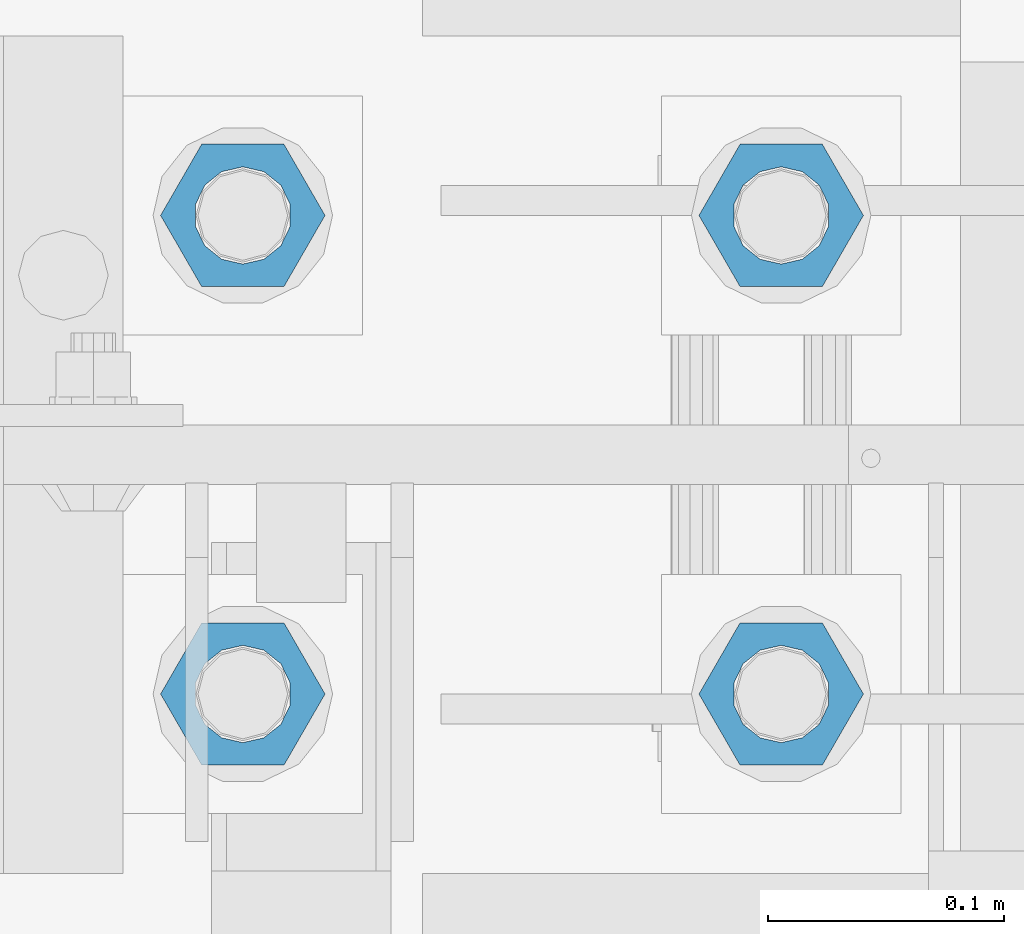
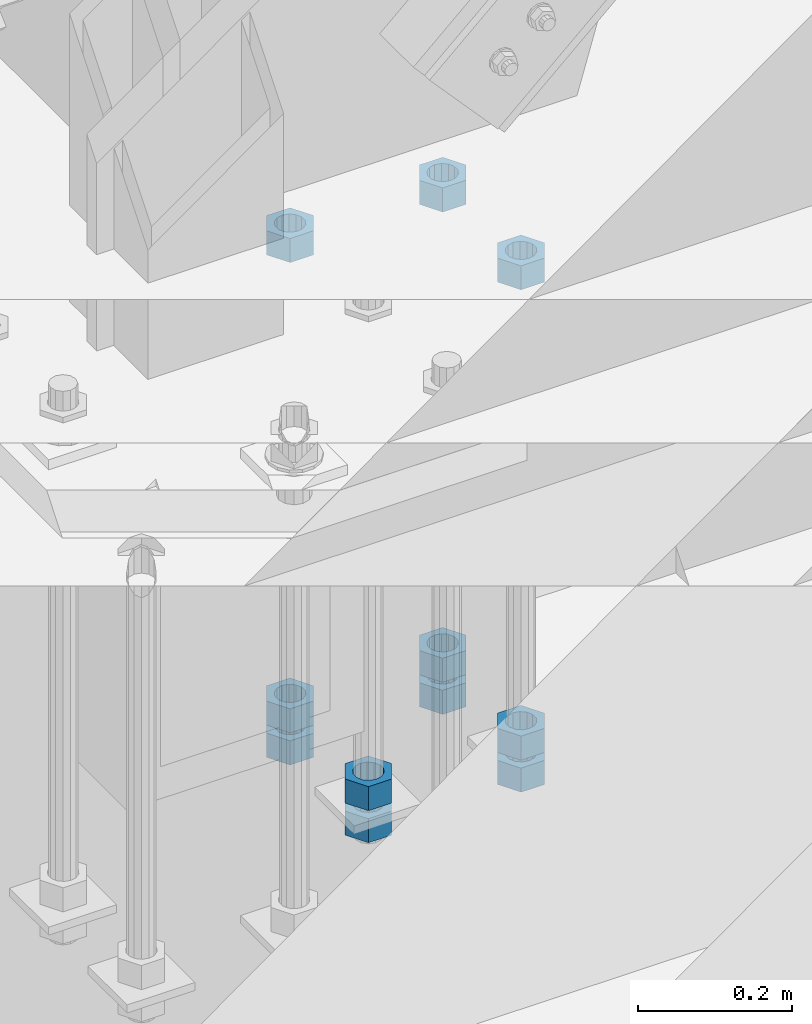
# One storey, part 980 of 1763: 11 columns, 1 element without a shape of its own.
"""IFC2X3 building model written with IfcOpenShell, lengths in millimetres."""

from ifc_helpers import new_model, si_unit, frame, origin_with_axes, place, context, subcontext, project, spatial, faceted_brep, material, type_object, element, aggregate, save


model = new_model("IFC2X3")

# Units and contexts
model_context = context("Model", 3, precision=1e-05, world=origin_with_axes())
body_context = subcontext(model_context, "Body", "Model", "MODEL_VIEW")
ifc_project = project(units=[si_unit("LENGTHUNIT", "METRE", prefix="MILLI"), si_unit("AREAUNIT", "SQUARE_METRE"), si_unit("VOLUMEUNIT", "CUBIC_METRE"), si_unit("MASSUNIT", "GRAM", prefix="KILO"), si_unit("TIMEUNIT", "SECOND"), si_unit("PLANEANGLEUNIT", "RADIAN"), si_unit("SOLIDANGLEUNIT", "STERADIAN"), si_unit("THERMODYNAMICTEMPERATUREUNIT", "DEGREE_CELSIUS"), si_unit("LUMINOUSINTENSITYUNIT", "LUMEN")], contexts=[model_context])

# Site, building, storey
site_placement = place(None, origin_with_axes())
site = spatial("IfcSite", under=ifc_project, at=site_placement, CompositionType="ELEMENT")
building_placement = place(site_placement, origin_with_axes())
building = spatial("IfcBuilding", under=site, at=building_placement, Name="Undefined", CompositionType="ELEMENT")
storey_placement = place(building_placement, origin_with_axes())
storey = spatial("IfcBuildingStorey", under=building, at=storey_placement, Name="Undefined", CompositionType="ELEMENT", Elevation=0.0)

# Assembly, columns
assembly_placement = place(storey_placement, origin_with_axes())
assembly = element("IfcElementAssembly", 1, at=assembly_placement, inside=storey, Name="TEMPLATE", AssemblyPlace="NOTDEFINED", PredefinedType="RIGID_FRAME")
ifc_material = material(Name="STEEL/A563")
column_type = type_object("IfcColumnType", Name="1-1/2_HEAVY_HEX_NUT", PredefinedType="NOTDEFINED")
column_1_placement = place(assembly_placement, frame((-87146.8372736983, -13817.6, 4445.00000000001), z_axis=(0.0, 1.0, 0.0), x_axis=(0.0, 0.0, -1.0)))
column_1 = element("IfcColumn", 2, at=column_1_placement, type_object=column_type, material=ifc_material, Name="NUT", ObjectType="1-1/2_HEAVY_HEX_NUT", context=body_context, shape_type="Brep", body=[
    faceted_brep([(0.0, -34.9199981689453, 0.0), (0.0, -17.4599990844727, -30.25), (38.1000000000004, -17.4599990844727, -30.25), (38.1000000000004, -34.9199981689453, 0.0), (0.0, 17.4599990844727, -30.25), (38.1000000000004, 17.4599990844727, -30.25), (0.0, 34.9199981689453, 0.0), (38.1000000000004, 34.9199981689453, 0.0), (0.0, 17.4599990844727, 30.25), (38.1000000000004, 17.4599990844727, 30.25), (0.0, -17.4599990844727, 30.25), (38.1000000000004, -17.4599990844727, 30.25), (0.0, 0.0, 20.6399993896484), (0.0, 8.95536011056538, 18.5959968835978), (38.1000000000004, 8.95536011056538, 18.5959968835978), (38.1000000000004, 0.0, 20.6399993896484), (0.0, 16.1370013209453, 12.8688291298167), (38.1000000000004, 16.1370013209453, 12.8688291298167), (0.0, 20.1225115123816, 4.59283194104137), (38.1000000000004, 20.1225115123816, 4.59283194104137), (0.0, 20.1225115123816, -4.59283194104319), (38.1000000000004, 20.1225115123816, -4.59283194104319), (0.0, 16.1370013209453, -12.8688291298167), (38.1000000000004, 16.1370013209453, -12.8688291298167), (0.0, 8.95536011056538, -18.5959968835978), (38.1000000000004, 8.95536011056538, -18.5959968835978), (0.0, 0.0, -20.6399993896484), (38.1000000000004, 0.0, -20.6399993896484), (0.0, -8.95536011056538, -18.5959968835978), (38.1000000000004, -8.95536011056538, -18.5959968835978), (0.0, -16.1370013209453, -12.8688291298167), (38.1000000000004, -16.1370013209453, -12.8688291298167), (0.0, -20.1225115123816, -4.59283194104137), (38.1000000000004, -20.1225115123816, -4.59283194104137), (0.0, -20.1225115123816, 4.59283194104319), (38.1000000000004, -20.1225115123816, 4.59283194104319), (0.0, -16.1370013209453, 12.8688291298167), (38.1000000000004, -16.1370013209453, 12.8688291298167), (0.0, -8.95536011056538, 18.5959968835978), (38.1000000000004, -8.95536011056538, 18.5959968835978)], [[[0, 1, 2, 3]], [[1, 4, 5, 2]], [[4, 6, 7, 5]], [[6, 8, 9, 7]], [[8, 10, 11, 9]], [[10, 0, 3, 11]], [[12, 13, 14, 15]], [[13, 16, 17, 14]], [[16, 18, 19, 17]], [[18, 20, 21, 19]], [[20, 22, 23, 21]], [[22, 24, 25, 23]], [[24, 26, 27, 25]], [[26, 28, 29, 27]], [[28, 30, 31, 29]], [[30, 32, 33, 31]], [[32, 34, 35, 33]], [[34, 36, 37, 35]], [[36, 38, 39, 37]], [[38, 12, 15, 39]], [[5, 7, 9, 11, 3, 2], [17, 19, 21, 23, 25, 27, 29, 31, 33, 35, 37, 39, 15, 14]], [[10, 8, 6, 4, 1, 0], [38, 36, 34, 32, 30, 28, 26, 24, 22, 20, 18, 16, 13, 12]]]),
])
column_2_placement = place(assembly_placement, frame((-87146.8372736983, -13817.6, 4394.20000000001), z_axis=(0.0, 1.0, 0.0), x_axis=(0.0, 0.0, -1.0)))
column_2 = element("IfcColumn", 3, at=column_2_placement, type_object=column_type, material=ifc_material, Name="NUT", ObjectType="1-1/2_HEAVY_HEX_NUT", context=body_context, shape_type="Brep", body=[
    faceted_brep([(0.0, -34.9199981689453, 0.0), (0.0, -17.4599990844727, -30.25), (38.1000000000004, -17.4599990844727, -30.25), (38.1000000000004, -34.9199981689453, 0.0), (0.0, 17.4599990844727, -30.25), (38.1000000000004, 17.4599990844727, -30.25), (0.0, 34.9199981689453, 0.0), (38.1000000000004, 34.9199981689453, 0.0), (0.0, 17.4599990844727, 30.25), (38.1000000000004, 17.4599990844727, 30.25), (0.0, -17.4599990844727, 30.25), (38.1000000000004, -17.4599990844727, 30.25), (0.0, 0.0, 20.6399993896484), (0.0, 8.95536011056538, 18.5959968835978), (38.1000000000004, 8.95536011056538, 18.5959968835978), (38.1000000000004, 0.0, 20.6399993896484), (0.0, 16.1370013209453, 12.8688291298167), (38.1000000000004, 16.1370013209453, 12.8688291298167), (0.0, 20.1225115123816, 4.59283194104137), (38.1000000000004, 20.1225115123816, 4.59283194104137), (0.0, 20.1225115123816, -4.59283194104319), (38.1000000000004, 20.1225115123816, -4.59283194104319), (0.0, 16.1370013209453, -12.8688291298167), (38.1000000000004, 16.1370013209453, -12.8688291298167), (0.0, 8.95536011056538, -18.5959968835978), (38.1000000000004, 8.95536011056538, -18.5959968835978), (0.0, 0.0, -20.6399993896484), (38.1000000000004, 0.0, -20.6399993896484), (0.0, -8.95536011056538, -18.5959968835978), (38.1000000000004, -8.95536011056538, -18.5959968835978), (0.0, -16.1370013209453, -12.8688291298167), (38.1000000000004, -16.1370013209453, -12.8688291298167), (0.0, -20.1225115123816, -4.59283194104137), (38.1000000000004, -20.1225115123816, -4.59283194104137), (0.0, -20.1225115123816, 4.59283194104319), (38.1000000000004, -20.1225115123816, 4.59283194104319), (0.0, -16.1370013209453, 12.8688291298167), (38.1000000000004, -16.1370013209453, 12.8688291298167), (0.0, -8.95536011056538, 18.5959968835978), (38.1000000000004, -8.95536011056538, 18.5959968835978)], [[[0, 1, 2, 3]], [[1, 4, 5, 2]], [[4, 6, 7, 5]], [[6, 8, 9, 7]], [[8, 10, 11, 9]], [[10, 0, 3, 11]], [[12, 13, 14, 15]], [[13, 16, 17, 14]], [[16, 18, 19, 17]], [[18, 20, 21, 19]], [[20, 22, 23, 21]], [[22, 24, 25, 23]], [[24, 26, 27, 25]], [[26, 28, 29, 27]], [[28, 30, 31, 29]], [[30, 32, 33, 31]], [[32, 34, 35, 33]], [[34, 36, 37, 35]], [[36, 38, 39, 37]], [[38, 12, 15, 39]], [[5, 7, 9, 11, 3, 2], [17, 19, 21, 23, 25, 27, 29, 31, 33, 35, 37, 39, 15, 14]], [[10, 8, 6, 4, 1, 0], [38, 36, 34, 32, 30, 28, 26, 24, 22, 20, 18, 16, 13, 12]]]),
])
column_3_placement = place(assembly_placement, frame((-86918.2372736983, -13817.6, 5189.53750000001), z_axis=(0.0, 1.0, 0.0), x_axis=(0.0, 0.0, -1.0)))
column_3 = element("IfcColumn", 4, at=column_3_placement, type_object=column_type, material=ifc_material, Name="NUT", ObjectType="1-1/2_HEAVY_HEX_NUT", context=body_context, shape_type="Brep", body=[
    faceted_brep([(0.0, -34.9199981689453, 0.0), (0.0, -17.4599990844727, -30.25), (38.1000000000004, -17.4599990844727, -30.25), (38.1000000000004, -34.9199981689453, 0.0), (0.0, 17.4599990844727, -30.25), (38.1000000000004, 17.4599990844727, -30.25), (0.0, 34.9199981689453, 0.0), (38.1000000000004, 34.9199981689453, 0.0), (0.0, 17.4599990844727, 30.25), (38.1000000000004, 17.4599990844727, 30.25), (0.0, -17.4599990844727, 30.25), (38.1000000000004, -17.4599990844727, 30.25), (0.0, 0.0, 20.6399993896484), (0.0, 8.95536011056538, 18.5959968835978), (38.1000000000004, 8.95536011056538, 18.5959968835978), (38.1000000000004, 0.0, 20.6399993896484), (0.0, 16.1370013209453, 12.8688291298167), (38.1000000000004, 16.1370013209453, 12.8688291298167), (0.0, 20.1225115123816, 4.59283194104137), (38.1000000000004, 20.1225115123816, 4.59283194104137), (0.0, 20.1225115123816, -4.59283194104319), (38.1000000000004, 20.1225115123816, -4.59283194104319), (0.0, 16.1370013209453, -12.8688291298167), (38.1000000000004, 16.1370013209453, -12.8688291298167), (0.0, 8.95536011056538, -18.5959968835978), (38.1000000000004, 8.95536011056538, -18.5959968835978), (0.0, 0.0, -20.6399993896484), (38.1000000000004, 0.0, -20.6399993896484), (0.0, -8.95536011056538, -18.5959968835978), (38.1000000000004, -8.95536011056538, -18.5959968835978), (0.0, -16.1370013209453, -12.8688291298167), (38.1000000000004, -16.1370013209453, -12.8688291298167), (0.0, -20.1225115123816, -4.59283194104137), (38.1000000000004, -20.1225115123816, -4.59283194104137), (0.0, -20.1225115123816, 4.59283194104319), (38.1000000000004, -20.1225115123816, 4.59283194104319), (0.0, -16.1370013209453, 12.8688291298167), (38.1000000000004, -16.1370013209453, 12.8688291298167), (0.0, -8.95536011056538, 18.5959968835978), (38.1000000000004, -8.95536011056538, 18.5959968835978)], [[[0, 1, 2, 3]], [[1, 4, 5, 2]], [[4, 6, 7, 5]], [[6, 8, 9, 7]], [[8, 10, 11, 9]], [[10, 0, 3, 11]], [[12, 13, 14, 15]], [[13, 16, 17, 14]], [[16, 18, 19, 17]], [[18, 20, 21, 19]], [[20, 22, 23, 21]], [[22, 24, 25, 23]], [[24, 26, 27, 25]], [[26, 28, 29, 27]], [[28, 30, 31, 29]], [[30, 32, 33, 31]], [[32, 34, 35, 33]], [[34, 36, 37, 35]], [[36, 38, 39, 37]], [[38, 12, 15, 39]], [[5, 7, 9, 11, 3, 2], [17, 19, 21, 23, 25, 27, 29, 31, 33, 35, 37, 39, 15, 14]], [[10, 8, 6, 4, 1, 0], [38, 36, 34, 32, 30, 28, 26, 24, 22, 20, 18, 16, 13, 12]]]),
])
column_4_placement = place(assembly_placement, frame((-86918.2372736983, -13817.6, 4445.00000000001), z_axis=(0.0, 1.0, 0.0), x_axis=(0.0, 0.0, -1.0)))
column_4 = element("IfcColumn", 5, at=column_4_placement, type_object=column_type, material=ifc_material, Name="NUT", ObjectType="1-1/2_HEAVY_HEX_NUT", context=body_context, shape_type="Brep", body=[
    faceted_brep([(0.0, -34.9199981689453, 0.0), (0.0, -17.4599990844727, -30.25), (38.1000000000004, -17.4599990844727, -30.25), (38.1000000000004, -34.9199981689453, 0.0), (0.0, 17.4599990844727, -30.25), (38.1000000000004, 17.4599990844727, -30.25), (0.0, 34.9199981689453, 0.0), (38.1000000000004, 34.9199981689453, 0.0), (0.0, 17.4599990844727, 30.25), (38.1000000000004, 17.4599990844727, 30.25), (0.0, -17.4599990844727, 30.25), (38.1000000000004, -17.4599990844727, 30.25), (0.0, 0.0, 20.6399993896484), (0.0, 8.95536011056538, 18.5959968835978), (38.1000000000004, 8.95536011056538, 18.5959968835978), (38.1000000000004, 0.0, 20.6399993896484), (0.0, 16.1370013209453, 12.8688291298167), (38.1000000000004, 16.1370013209453, 12.8688291298167), (0.0, 20.1225115123816, 4.59283194104137), (38.1000000000004, 20.1225115123816, 4.59283194104137), (0.0, 20.1225115123816, -4.59283194104319), (38.1000000000004, 20.1225115123816, -4.59283194104319), (0.0, 16.1370013209453, -12.8688291298167), (38.1000000000004, 16.1370013209453, -12.8688291298167), (0.0, 8.95536011056538, -18.5959968835978), (38.1000000000004, 8.95536011056538, -18.5959968835978), (0.0, 0.0, -20.6399993896484), (38.1000000000004, 0.0, -20.6399993896484), (0.0, -8.95536011056538, -18.5959968835978), (38.1000000000004, -8.95536011056538, -18.5959968835978), (0.0, -16.1370013209453, -12.8688291298167), (38.1000000000004, -16.1370013209453, -12.8688291298167), (0.0, -20.1225115123816, -4.59283194104137), (38.1000000000004, -20.1225115123816, -4.59283194104137), (0.0, -20.1225115123816, 4.59283194104319), (38.1000000000004, -20.1225115123816, 4.59283194104319), (0.0, -16.1370013209453, 12.8688291298167), (38.1000000000004, -16.1370013209453, 12.8688291298167), (0.0, -8.95536011056538, 18.5959968835978), (38.1000000000004, -8.95536011056538, 18.5959968835978)], [[[0, 1, 2, 3]], [[1, 4, 5, 2]], [[4, 6, 7, 5]], [[6, 8, 9, 7]], [[8, 10, 11, 9]], [[10, 0, 3, 11]], [[12, 13, 14, 15]], [[13, 16, 17, 14]], [[16, 18, 19, 17]], [[18, 20, 21, 19]], [[20, 22, 23, 21]], [[22, 24, 25, 23]], [[24, 26, 27, 25]], [[26, 28, 29, 27]], [[28, 30, 31, 29]], [[30, 32, 33, 31]], [[32, 34, 35, 33]], [[34, 36, 37, 35]], [[36, 38, 39, 37]], [[38, 12, 15, 39]], [[5, 7, 9, 11, 3, 2], [17, 19, 21, 23, 25, 27, 29, 31, 33, 35, 37, 39, 15, 14]], [[10, 8, 6, 4, 1, 0], [38, 36, 34, 32, 30, 28, 26, 24, 22, 20, 18, 16, 13, 12]]]),
])
column_5_placement = place(assembly_placement, frame((-86918.2372736983, -13817.6, 4394.20000000001), z_axis=(0.0, 1.0, 0.0), x_axis=(0.0, 0.0, -1.0)))
column_5 = element("IfcColumn", 6, at=column_5_placement, type_object=column_type, material=ifc_material, Name="NUT", ObjectType="1-1/2_HEAVY_HEX_NUT", context=body_context, shape_type="Brep", body=[
    faceted_brep([(0.0, -34.9199981689453, 0.0), (0.0, -17.4599990844727, -30.25), (38.1000000000004, -17.4599990844727, -30.25), (38.1000000000004, -34.9199981689453, 0.0), (0.0, 17.4599990844727, -30.25), (38.1000000000004, 17.4599990844727, -30.25), (0.0, 34.9199981689453, 0.0), (38.1000000000004, 34.9199981689453, 0.0), (0.0, 17.4599990844727, 30.25), (38.1000000000004, 17.4599990844727, 30.25), (0.0, -17.4599990844727, 30.25), (38.1000000000004, -17.4599990844727, 30.25), (0.0, 0.0, 20.6399993896484), (0.0, 8.95536011056538, 18.5959968835978), (38.1000000000004, 8.95536011056538, 18.5959968835978), (38.1000000000004, 0.0, 20.6399993896484), (0.0, 16.1370013209453, 12.8688291298167), (38.1000000000004, 16.1370013209453, 12.8688291298167), (0.0, 20.1225115123816, 4.59283194104137), (38.1000000000004, 20.1225115123816, 4.59283194104137), (0.0, 20.1225115123816, -4.59283194104319), (38.1000000000004, 20.1225115123816, -4.59283194104319), (0.0, 16.1370013209453, -12.8688291298167), (38.1000000000004, 16.1370013209453, -12.8688291298167), (0.0, 8.95536011056538, -18.5959968835978), (38.1000000000004, 8.95536011056538, -18.5959968835978), (0.0, 0.0, -20.6399993896484), (38.1000000000004, 0.0, -20.6399993896484), (0.0, -8.95536011056538, -18.5959968835978), (38.1000000000004, -8.95536011056538, -18.5959968835978), (0.0, -16.1370013209453, -12.8688291298167), (38.1000000000004, -16.1370013209453, -12.8688291298167), (0.0, -20.1225115123816, -4.59283194104137), (38.1000000000004, -20.1225115123816, -4.59283194104137), (0.0, -20.1225115123816, 4.59283194104319), (38.1000000000004, -20.1225115123816, 4.59283194104319), (0.0, -16.1370013209453, 12.8688291298167), (38.1000000000004, -16.1370013209453, 12.8688291298167), (0.0, -8.95536011056538, 18.5959968835978), (38.1000000000004, -8.95536011056538, 18.5959968835978)], [[[0, 1, 2, 3]], [[1, 4, 5, 2]], [[4, 6, 7, 5]], [[6, 8, 9, 7]], [[8, 10, 11, 9]], [[10, 0, 3, 11]], [[12, 13, 14, 15]], [[13, 16, 17, 14]], [[16, 18, 19, 17]], [[18, 20, 21, 19]], [[20, 22, 23, 21]], [[22, 24, 25, 23]], [[24, 26, 27, 25]], [[26, 28, 29, 27]], [[28, 30, 31, 29]], [[30, 32, 33, 31]], [[32, 34, 35, 33]], [[34, 36, 37, 35]], [[36, 38, 39, 37]], [[38, 12, 15, 39]], [[5, 7, 9, 11, 3, 2], [17, 19, 21, 23, 25, 27, 29, 31, 33, 35, 37, 39, 15, 14]], [[10, 8, 6, 4, 1, 0], [38, 36, 34, 32, 30, 28, 26, 24, 22, 20, 18, 16, 13, 12]]]),
])
column_6_placement = place(assembly_placement, frame((-87146.8372736983, -13614.4, 5189.53750000001), z_axis=(0.0, 1.0, 0.0), x_axis=(0.0, 0.0, -1.0)))
column_6 = element("IfcColumn", 7, at=column_6_placement, type_object=column_type, material=ifc_material, Name="NUT", ObjectType="1-1/2_HEAVY_HEX_NUT", context=body_context, shape_type="Brep", body=[
    faceted_brep([(0.0, -34.9199981689453, 0.0), (0.0, -17.4599990844727, -30.25), (38.1000000000004, -17.4599990844727, -30.25), (38.1000000000004, -34.9199981689453, 0.0), (0.0, 17.4599990844727, -30.25), (38.1000000000004, 17.4599990844727, -30.25), (0.0, 34.9199981689453, 0.0), (38.1000000000004, 34.9199981689453, 0.0), (0.0, 17.4599990844727, 30.25), (38.1000000000004, 17.4599990844727, 30.25), (0.0, -17.4599990844727, 30.25), (38.1000000000004, -17.4599990844727, 30.25), (0.0, 0.0, 20.6399993896484), (0.0, 8.95536011056538, 18.5959968835978), (38.1000000000004, 8.95536011056538, 18.5959968835978), (38.1000000000004, 0.0, 20.6399993896484), (0.0, 16.1370013209453, 12.8688291298167), (38.1000000000004, 16.1370013209453, 12.8688291298167), (0.0, 20.1225115123816, 4.59283194104137), (38.1000000000004, 20.1225115123816, 4.59283194104137), (0.0, 20.1225115123816, -4.59283194104319), (38.1000000000004, 20.1225115123816, -4.59283194104319), (0.0, 16.1370013209453, -12.8688291298167), (38.1000000000004, 16.1370013209453, -12.8688291298167), (0.0, 8.95536011056538, -18.5959968835978), (38.1000000000004, 8.95536011056538, -18.5959968835978), (0.0, 0.0, -20.6399993896484), (38.1000000000004, 0.0, -20.6399993896484), (0.0, -8.95536011056538, -18.5959968835978), (38.1000000000004, -8.95536011056538, -18.5959968835978), (0.0, -16.1370013209453, -12.8688291298167), (38.1000000000004, -16.1370013209453, -12.8688291298167), (0.0, -20.1225115123816, -4.59283194104137), (38.1000000000004, -20.1225115123816, -4.59283194104137), (0.0, -20.1225115123816, 4.59283194104319), (38.1000000000004, -20.1225115123816, 4.59283194104319), (0.0, -16.1370013209453, 12.8688291298167), (38.1000000000004, -16.1370013209453, 12.8688291298167), (0.0, -8.95536011056538, 18.5959968835978), (38.1000000000004, -8.95536011056538, 18.5959968835978)], [[[0, 1, 2, 3]], [[1, 4, 5, 2]], [[4, 6, 7, 5]], [[6, 8, 9, 7]], [[8, 10, 11, 9]], [[10, 0, 3, 11]], [[12, 13, 14, 15]], [[13, 16, 17, 14]], [[16, 18, 19, 17]], [[18, 20, 21, 19]], [[20, 22, 23, 21]], [[22, 24, 25, 23]], [[24, 26, 27, 25]], [[26, 28, 29, 27]], [[28, 30, 31, 29]], [[30, 32, 33, 31]], [[32, 34, 35, 33]], [[34, 36, 37, 35]], [[36, 38, 39, 37]], [[38, 12, 15, 39]], [[5, 7, 9, 11, 3, 2], [17, 19, 21, 23, 25, 27, 29, 31, 33, 35, 37, 39, 15, 14]], [[10, 8, 6, 4, 1, 0], [38, 36, 34, 32, 30, 28, 26, 24, 22, 20, 18, 16, 13, 12]]]),
])
column_7_placement = place(assembly_placement, frame((-87146.8372736983, -13614.4, 4445.00000000001), z_axis=(0.0, 1.0, 0.0), x_axis=(0.0, 0.0, -1.0)))
column_7 = element("IfcColumn", 8, at=column_7_placement, type_object=column_type, material=ifc_material, Name="NUT", ObjectType="1-1/2_HEAVY_HEX_NUT", context=body_context, shape_type="Brep", body=[
    faceted_brep([(0.0, -34.9199981689453, 0.0), (0.0, -17.4599990844727, -30.25), (38.1000000000004, -17.4599990844727, -30.25), (38.1000000000004, -34.9199981689453, 0.0), (0.0, 17.4599990844727, -30.25), (38.1000000000004, 17.4599990844727, -30.25), (0.0, 34.9199981689453, 0.0), (38.1000000000004, 34.9199981689453, 0.0), (0.0, 17.4599990844727, 30.25), (38.1000000000004, 17.4599990844727, 30.25), (0.0, -17.4599990844727, 30.25), (38.1000000000004, -17.4599990844727, 30.25), (0.0, 0.0, 20.6399993896484), (0.0, 8.95536011056538, 18.5959968835978), (38.1000000000004, 8.95536011056538, 18.5959968835978), (38.1000000000004, 0.0, 20.6399993896484), (0.0, 16.1370013209453, 12.8688291298167), (38.1000000000004, 16.1370013209453, 12.8688291298167), (0.0, 20.1225115123816, 4.59283194104137), (38.1000000000004, 20.1225115123816, 4.59283194104137), (0.0, 20.1225115123816, -4.59283194104319), (38.1000000000004, 20.1225115123816, -4.59283194104319), (0.0, 16.1370013209453, -12.8688291298167), (38.1000000000004, 16.1370013209453, -12.8688291298167), (0.0, 8.95536011056538, -18.5959968835978), (38.1000000000004, 8.95536011056538, -18.5959968835978), (0.0, 0.0, -20.6399993896484), (38.1000000000004, 0.0, -20.6399993896484), (0.0, -8.95536011056538, -18.5959968835978), (38.1000000000004, -8.95536011056538, -18.5959968835978), (0.0, -16.1370013209453, -12.8688291298167), (38.1000000000004, -16.1370013209453, -12.8688291298167), (0.0, -20.1225115123816, -4.59283194104137), (38.1000000000004, -20.1225115123816, -4.59283194104137), (0.0, -20.1225115123816, 4.59283194104319), (38.1000000000004, -20.1225115123816, 4.59283194104319), (0.0, -16.1370013209453, 12.8688291298167), (38.1000000000004, -16.1370013209453, 12.8688291298167), (0.0, -8.95536011056538, 18.5959968835978), (38.1000000000004, -8.95536011056538, 18.5959968835978)], [[[0, 1, 2, 3]], [[1, 4, 5, 2]], [[4, 6, 7, 5]], [[6, 8, 9, 7]], [[8, 10, 11, 9]], [[10, 0, 3, 11]], [[12, 13, 14, 15]], [[13, 16, 17, 14]], [[16, 18, 19, 17]], [[18, 20, 21, 19]], [[20, 22, 23, 21]], [[22, 24, 25, 23]], [[24, 26, 27, 25]], [[26, 28, 29, 27]], [[28, 30, 31, 29]], [[30, 32, 33, 31]], [[32, 34, 35, 33]], [[34, 36, 37, 35]], [[36, 38, 39, 37]], [[38, 12, 15, 39]], [[5, 7, 9, 11, 3, 2], [17, 19, 21, 23, 25, 27, 29, 31, 33, 35, 37, 39, 15, 14]], [[10, 8, 6, 4, 1, 0], [38, 36, 34, 32, 30, 28, 26, 24, 22, 20, 18, 16, 13, 12]]]),
])
column_8_placement = place(assembly_placement, frame((-87146.8372736983, -13614.4, 4394.20000000001), z_axis=(0.0, 1.0, 0.0), x_axis=(0.0, 0.0, -1.0)))
column_8 = element("IfcColumn", 9, at=column_8_placement, type_object=column_type, material=ifc_material, Name="NUT", ObjectType="1-1/2_HEAVY_HEX_NUT", context=body_context, shape_type="Brep", body=[
    faceted_brep([(0.0, -34.9199981689453, 0.0), (0.0, -17.4599990844727, -30.25), (38.1000000000004, -17.4599990844727, -30.25), (38.1000000000004, -34.9199981689453, 0.0), (0.0, 17.4599990844727, -30.25), (38.1000000000004, 17.4599990844727, -30.25), (0.0, 34.9199981689453, 0.0), (38.1000000000004, 34.9199981689453, 0.0), (0.0, 17.4599990844727, 30.25), (38.1000000000004, 17.4599990844727, 30.25), (0.0, -17.4599990844727, 30.25), (38.1000000000004, -17.4599990844727, 30.25), (0.0, 0.0, 20.6399993896484), (0.0, 8.95536011056538, 18.5959968835978), (38.1000000000004, 8.95536011056538, 18.5959968835978), (38.1000000000004, 0.0, 20.6399993896484), (0.0, 16.1370013209453, 12.8688291298167), (38.1000000000004, 16.1370013209453, 12.8688291298167), (0.0, 20.1225115123816, 4.59283194104137), (38.1000000000004, 20.1225115123816, 4.59283194104137), (0.0, 20.1225115123816, -4.59283194104319), (38.1000000000004, 20.1225115123816, -4.59283194104319), (0.0, 16.1370013209453, -12.8688291298167), (38.1000000000004, 16.1370013209453, -12.8688291298167), (0.0, 8.95536011056538, -18.5959968835978), (38.1000000000004, 8.95536011056538, -18.5959968835978), (0.0, 0.0, -20.6399993896484), (38.1000000000004, 0.0, -20.6399993896484), (0.0, -8.95536011056538, -18.5959968835978), (38.1000000000004, -8.95536011056538, -18.5959968835978), (0.0, -16.1370013209453, -12.8688291298167), (38.1000000000004, -16.1370013209453, -12.8688291298167), (0.0, -20.1225115123816, -4.59283194104137), (38.1000000000004, -20.1225115123816, -4.59283194104137), (0.0, -20.1225115123816, 4.59283194104319), (38.1000000000004, -20.1225115123816, 4.59283194104319), (0.0, -16.1370013209453, 12.8688291298167), (38.1000000000004, -16.1370013209453, 12.8688291298167), (0.0, -8.95536011056538, 18.5959968835978), (38.1000000000004, -8.95536011056538, 18.5959968835978)], [[[0, 1, 2, 3]], [[1, 4, 5, 2]], [[4, 6, 7, 5]], [[6, 8, 9, 7]], [[8, 10, 11, 9]], [[10, 0, 3, 11]], [[12, 13, 14, 15]], [[13, 16, 17, 14]], [[16, 18, 19, 17]], [[18, 20, 21, 19]], [[20, 22, 23, 21]], [[22, 24, 25, 23]], [[24, 26, 27, 25]], [[26, 28, 29, 27]], [[28, 30, 31, 29]], [[30, 32, 33, 31]], [[32, 34, 35, 33]], [[34, 36, 37, 35]], [[36, 38, 39, 37]], [[38, 12, 15, 39]], [[5, 7, 9, 11, 3, 2], [17, 19, 21, 23, 25, 27, 29, 31, 33, 35, 37, 39, 15, 14]], [[10, 8, 6, 4, 1, 0], [38, 36, 34, 32, 30, 28, 26, 24, 22, 20, 18, 16, 13, 12]]]),
])
column_9_placement = place(assembly_placement, frame((-86918.2372736983, -13614.4, 5189.53750000001), z_axis=(0.0, 1.0, 0.0), x_axis=(0.0, 0.0, -1.0)))
column_9 = element("IfcColumn", 10, at=column_9_placement, type_object=column_type, material=ifc_material, Name="NUT", ObjectType="1-1/2_HEAVY_HEX_NUT", context=body_context, shape_type="Brep", body=[
    faceted_brep([(0.0, -34.9199981689453, 0.0), (0.0, -17.4599990844727, -30.25), (38.1000000000004, -17.4599990844727, -30.25), (38.1000000000004, -34.9199981689453, 0.0), (0.0, 17.4599990844727, -30.25), (38.1000000000004, 17.4599990844727, -30.25), (0.0, 34.9199981689453, 0.0), (38.1000000000004, 34.9199981689453, 0.0), (0.0, 17.4599990844727, 30.25), (38.1000000000004, 17.4599990844727, 30.25), (0.0, -17.4599990844727, 30.25), (38.1000000000004, -17.4599990844727, 30.25), (0.0, 0.0, 20.6399993896484), (0.0, 8.95536011056538, 18.5959968835978), (38.1000000000004, 8.95536011056538, 18.5959968835978), (38.1000000000004, 0.0, 20.6399993896484), (0.0, 16.1370013209453, 12.8688291298167), (38.1000000000004, 16.1370013209453, 12.8688291298167), (0.0, 20.1225115123816, 4.59283194104137), (38.1000000000004, 20.1225115123816, 4.59283194104137), (0.0, 20.1225115123816, -4.59283194104319), (38.1000000000004, 20.1225115123816, -4.59283194104319), (0.0, 16.1370013209453, -12.8688291298167), (38.1000000000004, 16.1370013209453, -12.8688291298167), (0.0, 8.95536011056538, -18.5959968835978), (38.1000000000004, 8.95536011056538, -18.5959968835978), (0.0, 0.0, -20.6399993896484), (38.1000000000004, 0.0, -20.6399993896484), (0.0, -8.95536011056538, -18.5959968835978), (38.1000000000004, -8.95536011056538, -18.5959968835978), (0.0, -16.1370013209453, -12.8688291298167), (38.1000000000004, -16.1370013209453, -12.8688291298167), (0.0, -20.1225115123816, -4.59283194104137), (38.1000000000004, -20.1225115123816, -4.59283194104137), (0.0, -20.1225115123816, 4.59283194104319), (38.1000000000004, -20.1225115123816, 4.59283194104319), (0.0, -16.1370013209453, 12.8688291298167), (38.1000000000004, -16.1370013209453, 12.8688291298167), (0.0, -8.95536011056538, 18.5959968835978), (38.1000000000004, -8.95536011056538, 18.5959968835978)], [[[0, 1, 2, 3]], [[1, 4, 5, 2]], [[4, 6, 7, 5]], [[6, 8, 9, 7]], [[8, 10, 11, 9]], [[10, 0, 3, 11]], [[12, 13, 14, 15]], [[13, 16, 17, 14]], [[16, 18, 19, 17]], [[18, 20, 21, 19]], [[20, 22, 23, 21]], [[22, 24, 25, 23]], [[24, 26, 27, 25]], [[26, 28, 29, 27]], [[28, 30, 31, 29]], [[30, 32, 33, 31]], [[32, 34, 35, 33]], [[34, 36, 37, 35]], [[36, 38, 39, 37]], [[38, 12, 15, 39]], [[5, 7, 9, 11, 3, 2], [17, 19, 21, 23, 25, 27, 29, 31, 33, 35, 37, 39, 15, 14]], [[10, 8, 6, 4, 1, 0], [38, 36, 34, 32, 30, 28, 26, 24, 22, 20, 18, 16, 13, 12]]]),
])
column_10_placement = place(assembly_placement, frame((-86918.2372736983, -13614.4, 4445.00000000001), z_axis=(0.0, 1.0, 0.0), x_axis=(0.0, 0.0, -1.0)))
column_10 = element("IfcColumn", 11, at=column_10_placement, type_object=column_type, material=ifc_material, Name="NUT", ObjectType="1-1/2_HEAVY_HEX_NUT", context=body_context, shape_type="Brep", body=[
    faceted_brep([(0.0, -34.9199981689453, 0.0), (0.0, -17.4599990844727, -30.25), (38.1000000000004, -17.4599990844727, -30.25), (38.1000000000004, -34.9199981689453, 0.0), (0.0, 17.4599990844727, -30.25), (38.1000000000004, 17.4599990844727, -30.25), (0.0, 34.9199981689453, 0.0), (38.1000000000004, 34.9199981689453, 0.0), (0.0, 17.4599990844727, 30.25), (38.1000000000004, 17.4599990844727, 30.25), (0.0, -17.4599990844727, 30.25), (38.1000000000004, -17.4599990844727, 30.25), (0.0, 0.0, 20.6399993896484), (0.0, 8.95536011056538, 18.5959968835978), (38.1000000000004, 8.95536011056538, 18.5959968835978), (38.1000000000004, 0.0, 20.6399993896484), (0.0, 16.1370013209453, 12.8688291298167), (38.1000000000004, 16.1370013209453, 12.8688291298167), (0.0, 20.1225115123816, 4.59283194104137), (38.1000000000004, 20.1225115123816, 4.59283194104137), (0.0, 20.1225115123816, -4.59283194104319), (38.1000000000004, 20.1225115123816, -4.59283194104319), (0.0, 16.1370013209453, -12.8688291298167), (38.1000000000004, 16.1370013209453, -12.8688291298167), (0.0, 8.95536011056538, -18.5959968835978), (38.1000000000004, 8.95536011056538, -18.5959968835978), (0.0, 0.0, -20.6399993896484), (38.1000000000004, 0.0, -20.6399993896484), (0.0, -8.95536011056538, -18.5959968835978), (38.1000000000004, -8.95536011056538, -18.5959968835978), (0.0, -16.1370013209453, -12.8688291298167), (38.1000000000004, -16.1370013209453, -12.8688291298167), (0.0, -20.1225115123816, -4.59283194104137), (38.1000000000004, -20.1225115123816, -4.59283194104137), (0.0, -20.1225115123816, 4.59283194104319), (38.1000000000004, -20.1225115123816, 4.59283194104319), (0.0, -16.1370013209453, 12.8688291298167), (38.1000000000004, -16.1370013209453, 12.8688291298167), (0.0, -8.95536011056538, 18.5959968835978), (38.1000000000004, -8.95536011056538, 18.5959968835978)], [[[0, 1, 2, 3]], [[1, 4, 5, 2]], [[4, 6, 7, 5]], [[6, 8, 9, 7]], [[8, 10, 11, 9]], [[10, 0, 3, 11]], [[12, 13, 14, 15]], [[13, 16, 17, 14]], [[16, 18, 19, 17]], [[18, 20, 21, 19]], [[20, 22, 23, 21]], [[22, 24, 25, 23]], [[24, 26, 27, 25]], [[26, 28, 29, 27]], [[28, 30, 31, 29]], [[30, 32, 33, 31]], [[32, 34, 35, 33]], [[34, 36, 37, 35]], [[36, 38, 39, 37]], [[38, 12, 15, 39]], [[5, 7, 9, 11, 3, 2], [17, 19, 21, 23, 25, 27, 29, 31, 33, 35, 37, 39, 15, 14]], [[10, 8, 6, 4, 1, 0], [38, 36, 34, 32, 30, 28, 26, 24, 22, 20, 18, 16, 13, 12]]]),
])
column_11_placement = place(assembly_placement, frame((-86918.2372736983, -13614.4, 4394.20000000001), z_axis=(0.0, 1.0, 0.0), x_axis=(0.0, 0.0, -1.0)))
column_11 = element("IfcColumn", 12, at=column_11_placement, type_object=column_type, material=ifc_material, Name="NUT", ObjectType="1-1/2_HEAVY_HEX_NUT", context=body_context, shape_type="Brep", body=[
    faceted_brep([(0.0, -34.9199981689453, 0.0), (0.0, -17.4599990844727, -30.25), (38.1000000000004, -17.4599990844727, -30.25), (38.1000000000004, -34.9199981689453, 0.0), (0.0, 17.4599990844727, -30.25), (38.1000000000004, 17.4599990844727, -30.25), (0.0, 34.9199981689453, 0.0), (38.1000000000004, 34.9199981689453, 0.0), (0.0, 17.4599990844727, 30.25), (38.1000000000004, 17.4599990844727, 30.25), (0.0, -17.4599990844727, 30.25), (38.1000000000004, -17.4599990844727, 30.25), (0.0, 0.0, 20.6399993896484), (0.0, 8.95536011056538, 18.5959968835978), (38.1000000000004, 8.95536011056538, 18.5959968835978), (38.1000000000004, 0.0, 20.6399993896484), (0.0, 16.1370013209453, 12.8688291298167), (38.1000000000004, 16.1370013209453, 12.8688291298167), (0.0, 20.1225115123816, 4.59283194104137), (38.1000000000004, 20.1225115123816, 4.59283194104137), (0.0, 20.1225115123816, -4.59283194104319), (38.1000000000004, 20.1225115123816, -4.59283194104319), (0.0, 16.1370013209453, -12.8688291298167), (38.1000000000004, 16.1370013209453, -12.8688291298167), (0.0, 8.95536011056538, -18.5959968835978), (38.1000000000004, 8.95536011056538, -18.5959968835978), (0.0, 0.0, -20.6399993896484), (38.1000000000004, 0.0, -20.6399993896484), (0.0, -8.95536011056538, -18.5959968835978), (38.1000000000004, -8.95536011056538, -18.5959968835978), (0.0, -16.1370013209453, -12.8688291298167), (38.1000000000004, -16.1370013209453, -12.8688291298167), (0.0, -20.1225115123816, -4.59283194104137), (38.1000000000004, -20.1225115123816, -4.59283194104137), (0.0, -20.1225115123816, 4.59283194104319), (38.1000000000004, -20.1225115123816, 4.59283194104319), (0.0, -16.1370013209453, 12.8688291298167), (38.1000000000004, -16.1370013209453, 12.8688291298167), (0.0, -8.95536011056538, 18.5959968835978), (38.1000000000004, -8.95536011056538, 18.5959968835978)], [[[0, 1, 2, 3]], [[1, 4, 5, 2]], [[4, 6, 7, 5]], [[6, 8, 9, 7]], [[8, 10, 11, 9]], [[10, 0, 3, 11]], [[12, 13, 14, 15]], [[13, 16, 17, 14]], [[16, 18, 19, 17]], [[18, 20, 21, 19]], [[20, 22, 23, 21]], [[22, 24, 25, 23]], [[24, 26, 27, 25]], [[26, 28, 29, 27]], [[28, 30, 31, 29]], [[30, 32, 33, 31]], [[32, 34, 35, 33]], [[34, 36, 37, 35]], [[36, 38, 39, 37]], [[38, 12, 15, 39]], [[5, 7, 9, 11, 3, 2], [17, 19, 21, 23, 25, 27, 29, 31, 33, 35, 37, 39, 15, 14]], [[10, 8, 6, 4, 1, 0], [38, 36, 34, 32, 30, 28, 26, 24, 22, 20, 18, 16, 13, 12]]]),
])
aggregate(assembly, [column_1, column_2, column_3, column_4, column_5, column_6, column_7, column_8, column_9, column_10, column_11])

save(model, "model.ifc")
